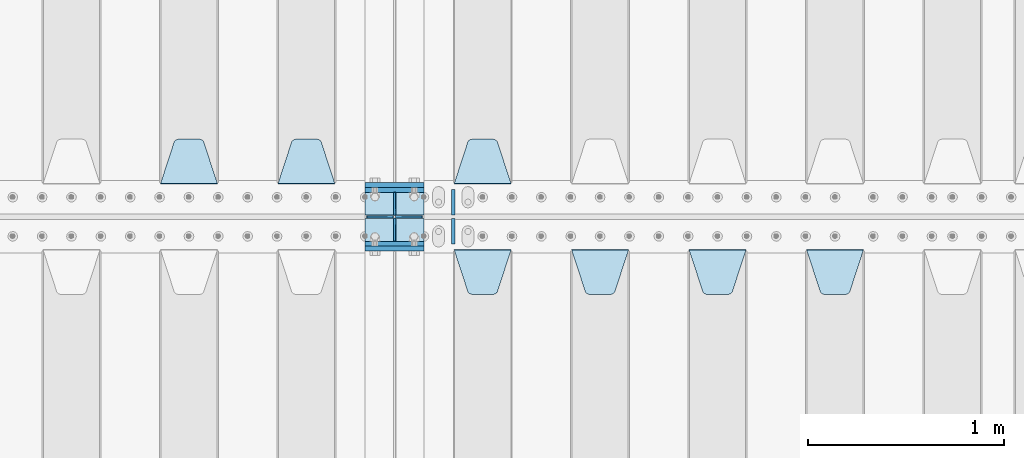
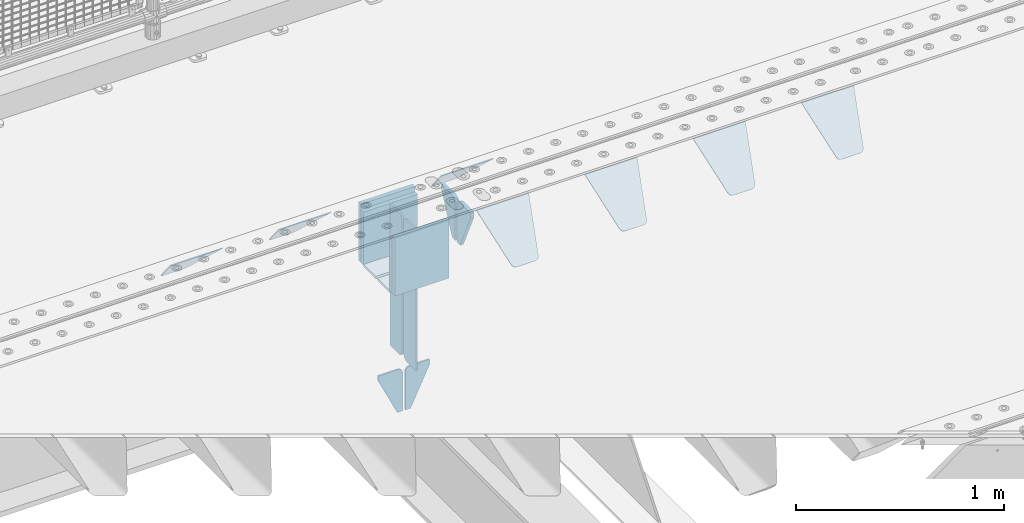
# One storey, part 227 of 257: 21 plates.
"""IFC2X3 building model written with IfcOpenShell, lengths in millimetres."""

from ifc_helpers import new_model, si_unit, frame, origin_with_axes, place, context, subcontext, project, spatial, faceted_brep, material, type_object, element, save


model = new_model("IFC2X3")

# Units and contexts
model_context = context("Model", 3, precision=1e-05, world=origin_with_axes())
body_context = subcontext(model_context, "Body", "Model", "MODEL_VIEW")
ifc_project = project(units=[si_unit("LENGTHUNIT", "METRE", prefix="MILLI"), si_unit("AREAUNIT", "SQUARE_METRE"), si_unit("VOLUMEUNIT", "CUBIC_METRE"), si_unit("MASSUNIT", "GRAM", prefix="KILO"), si_unit("TIMEUNIT", "SECOND"), si_unit("PLANEANGLEUNIT", "RADIAN"), si_unit("SOLIDANGLEUNIT", "STERADIAN"), si_unit("THERMODYNAMICTEMPERATUREUNIT", "DEGREE_CELSIUS"), si_unit("LUMINOUSINTENSITYUNIT", "LUMEN")], contexts=[model_context])

# Site, building, storey
site_placement = place(None, origin_with_axes())
site = spatial("IfcSite", under=ifc_project, at=site_placement, CompositionType="ELEMENT")
building_placement = place(site_placement, origin_with_axes())
building = spatial("IfcBuilding", under=site, at=building_placement, Name="Standard", CompositionType="ELEMENT")
storey_placement = place(building_placement, origin_with_axes())
storey = spatial("IfcBuildingStorey", under=building, at=storey_placement, Name="Undefined", CompositionType="ELEMENT", Elevation=0.0)

# Plates
ifc_material = material(Name="STEEL/S355N")
plate_type_1 = type_object("IfcPlateType", PredefinedType="NOTDEFINED")
for number, where, z_axis, x_axis in (
    (1, (54550.0, 8837.5, -340.000000000044), (0.0, 0.0, 1.0), (1.0, 0.0, 0.0)),
    (2, (54550.0, 9162.5, -340.000000000044), (0.0, 0.0, 1.0), (1.0, 0.0, 0.0)),
):
    element("IfcPlate", number, at=place(storey_placement, frame(where, z_axis=z_axis, x_axis=x_axis)), inside=storey, type_object=plate_type_1, material=ifc_material, context=body_context, shape_type="Brep", body=[
        faceted_brep([(0.0, -12.5, 0.0), (0.0, -12.5, 340.0), (0.0, 12.5, 340.0), (0.0, 12.5, 0.0), (300.0, -12.5, 340.0), (300.0, 12.5, 340.0), (300.0, -12.5, 0.0), (300.0, 12.5, 0.0)], [[[0, 1, 2, 3]], [[1, 4, 5, 2]], [[4, 6, 7, 5]], [[6, 0, 3, 7]], [[5, 7, 3, 2]], [[6, 4, 1, 0]]]),
    ])
for number, where, z_axis, x_axis in (
    (3, (54550.0, 9137.5, -340.0), (0.0, 0.0, 1.0), (1.0, 0.0, 0.0)),
    (4, (54550.0, 8862.5, -340.0), (0.0, 0.0, 1.0), (1.0, 0.0, 0.0)),
):
    element("IfcPlate", number, at=place(storey_placement, frame(where, z_axis=z_axis, x_axis=x_axis)), inside=storey, type_object=plate_type_1, material=ifc_material, context=body_context, shape_type="Brep", body=[
        faceted_brep([(0.0, -12.5, 0.0), (0.0, -12.5, 310.0), (0.0, 12.5, 310.0), (0.0, 12.5, 0.0), (300.0, -12.5, 310.0), (300.0, 12.5, 310.0), (300.0, -12.5, 0.0), (300.0, 12.5, 0.0)], [[[0, 1, 2, 3]], [[1, 4, 5, 2]], [[4, 6, 7, 5]], [[6, 0, 3, 7]], [[5, 7, 3, 2]], [[6, 4, 1, 0]]]),
    ])
plate_type_2 = type_object("IfcPlateType", PredefinedType="NOTDEFINED")
for number, where, z_axis, x_axis in (
    (5, (54550.0, 8992.0, -343.0), (0.0, -1.0, 0.0), (1.0, 0.0, 0.0)),
    (6, (54550.0, 9008.0, -343.0), (0.0, 1.0, 0.0), (1.0, 0.0, 0.0)),
):
    element("IfcPlate", number, at=place(storey_placement, frame(where, z_axis=z_axis, x_axis=x_axis)), inside=storey, type_object=plate_type_2, material=ifc_material, context=body_context, shape_type="Brep", body=[
        faceted_brep([(0.0, -7.0, 0.0), (0.0, -7.0, 117.0), (0.0, 7.0, 117.0), (0.0, 7.0, 0.0), (300.0, -7.0, 117.0), (300.0, 7.0, 117.0), (300.0, -7.0, 0.0), (300.0, 7.0, 0.0)], [[[0, 1, 2, 3]], [[1, 4, 5, 2]], [[4, 6, 7, 5]], [[6, 0, 3, 7]], [[5, 7, 3, 2]], [[6, 4, 1, 0]]]),
    ])
plate_type_3 = type_object("IfcPlateType", PredefinedType="NOTDEFINED")
for number, where, z_axis, x_axis in (
    (7, (54700.0, 8992.0, -350.0), (0.0, 0.0, -1.0), (0.0, -1.0, 0.0)),
    (8, (54700.0, 9008.0, -350.0), (0.0, 0.0, -1.0), (0.0, 1.0, 0.0)),
):
    element("IfcPlate", number, at=place(storey_placement, frame(where, z_axis=z_axis, x_axis=x_axis)), inside=storey, type_object=plate_type_3, material=ifc_material, context=body_context, shape_type="Brep", body=[
        faceted_brep([(0.0, -5.0, 0.0), (0.0, -5.0, 480.0), (0.0, 5.0, 480.0), (0.0, 5.0, 0.0), (0.455767409633609, -5.0, 485.209445330008), (0.455767409633609, 5.0, 485.209445330008), (1.80922137642256, -5.0, 490.26060429977), (1.80922137642256, 5.0, 490.26060429977), (4.01923788646673, -5.0, 495.0), (4.01923788646673, 5.0, 495.0), (7.01866670643085, -5.0, 499.283628290596), (7.01866670643085, 5.0, 499.283628290596), (10.716371709404, -5.0, 502.981333293569), (10.716371709404, 5.0, 502.981333293569), (15.0, -5.0, 505.980762113533), (15.0, 5.0, 505.980762113533), (19.73939570023, -5.0, 508.190778623577), (19.73939570023, 5.0, 508.190778623577), (24.7905546699922, -5.0, 509.544232590366), (24.7905546699922, 5.0, 509.544232590366), (30.0, -5.0, 510.0), (30.0, 5.0, 510.0), (117.0, -5.0, 510.0), (117.0, 5.0, 510.0), (117.0, -5.0, 0.0), (117.0, 5.0, 0.0)], [[[0, 1, 2, 3]], [[1, 4, 5, 2]], [[4, 6, 7, 5]], [[6, 8, 9, 7]], [[8, 10, 11, 9]], [[10, 12, 13, 11]], [[12, 14, 15, 13]], [[14, 16, 17, 15]], [[16, 18, 19, 17]], [[18, 20, 21, 19]], [[20, 22, 23, 21]], [[22, 24, 25, 23]], [[24, 0, 3, 25]], [[5, 7, 9, 11, 13, 15, 17, 19, 21, 23, 25, 3, 2]], [[24, 22, 20, 18, 16, 14, 12, 10, 8, 6, 4, 1, 0]]]),
    ])
for number, where, z_axis, x_axis in (
    (9, (54700.0, 9008.0, -30.0), (0.0, 0.0, -1.0), (0.0, 1.0, 0.0)),
    (10, (54700.0, 8992.0, -30.0), (0.0, 0.0, -1.0), (0.0, -1.0, 0.0)),
):
    element("IfcPlate", number, at=place(storey_placement, frame(where, z_axis=z_axis, x_axis=x_axis)), inside=storey, type_object=plate_type_3, material=ifc_material, context=body_context, shape_type="Brep", body=[
        faceted_brep([(0.0, -5.0, 30.0), (0.0, -5.0, 306.0), (0.0, 5.0, 306.0), (0.0, 5.0, 30.0), (117.0, -5.0, 306.0), (117.0, 5.0, 306.0), (117.0, -5.0, 0.0), (117.0, 5.0, 0.0), (30.0, -5.0, 0.0), (30.0, 5.0, 0.0), (24.7905546699922, -5.0, 0.455767409633758), (24.7905546699922, 5.0, 0.455767409633758), (19.7393957002296, -5.0, 1.80922137642275), (19.7393957002296, 5.0, 1.80922137642275), (15.0, -5.0, 4.01923788646684), (15.0, 5.0, 4.01923788646684), (10.7163717094036, -5.0, 7.01866670643066), (10.7163717094036, 5.0, 7.01866670643066), (7.01866670643085, -5.0, 10.7163717094038), (7.01866670643085, 5.0, 10.7163717094038), (4.01923788646673, -5.0, 15.0), (4.01923788646673, 5.0, 15.0), (1.80922137642301, -5.0, 19.7393957002299), (1.80922137642301, 5.0, 19.7393957002299), (0.455767409634063, -5.0, 24.7905546699921), (0.455767409634063, 5.0, 24.7905546699921)], [[[0, 1, 2, 3]], [[1, 4, 5, 2]], [[4, 6, 7, 5]], [[6, 8, 9, 7]], [[8, 10, 11, 9]], [[10, 12, 13, 11]], [[12, 14, 15, 13]], [[14, 16, 17, 15]], [[16, 18, 19, 17]], [[18, 20, 21, 19]], [[20, 22, 23, 21]], [[22, 24, 25, 23]], [[24, 0, 3, 25]], [[5, 7, 9, 11, 13, 15, 17, 19, 21, 23, 25, 3, 2]], [[24, 22, 20, 18, 16, 14, 12, 10, 8, 6, 4, 1, 0]]]),
    ])
plate_type_4 = type_object("IfcPlateType", PredefinedType="NOTDEFINED")
for number, where, z_axis, x_axis in (
    (11, (54693.499999997, 9000.00000000422, -915.000019536854), (0.0, 0.0, -1.0), (-1.0, 0.0, 0.0)),
    (12, (54706.4999999972, 9000.0000000042, -915.000019536855), (0.0, 0.0, -1.0), (1.0, 0.0, 0.0)),
):
    element("IfcPlate", number, at=place(storey_placement, frame(where, z_axis=z_axis, x_axis=x_axis)), inside=storey, type_object=plate_type_4, material=ifc_material, context=body_context, shape_type="Brep", body=[
        faceted_brep([(0.0, -5.0, 27.0), (0.0, -5.0, 250.0), (0.0, 5.0, 250.0), (0.0, 5.0, 27.0), (30.0, -5.0, 250.0), (30.0, 5.0, 250.0), (135.0, -5.0, 30.0), (135.0, 5.0, 30.0), (135.0, -5.0, 0.0), (135.0, 5.0, 0.0), (27.0, -5.0, 0.0), (27.0, 5.0, 0.0), (22.311499202995, -5.0, 0.410190668670339), (22.311499202995, 5.0, 0.410190668670339), (17.7654561302043, -5.0, 1.62829923878053), (17.7654561302043, 5.0, 1.62829923878053), (13.5, -5.0, 3.6173140978201), (13.5, 5.0, 3.6173140978201), (9.64473453846585, -5.0, 6.31680003578754), (9.64473453846585, 5.0, 6.31680003578754), (6.31680003579095, -5.0, 9.64473453846347), (6.31680003579095, 5.0, 9.64473453846347), (3.61731409782078, -5.0, 13.5), (3.61731409782078, 5.0, 13.5), (1.62829923877871, -5.0, 17.765456130207), (1.62829923877871, 5.0, 17.765456130207), (0.410190668670111, -5.0, 22.3114992029929), (0.410190668670111, 5.0, 22.3114992029929)], [[[0, 1, 2, 3]], [[1, 4, 5, 2]], [[4, 6, 7, 5]], [[6, 8, 9, 7]], [[8, 10, 11, 9]], [[10, 12, 13, 11]], [[12, 14, 15, 13]], [[14, 16, 17, 15]], [[16, 18, 19, 17]], [[18, 20, 21, 19]], [[20, 22, 23, 21]], [[22, 24, 25, 23]], [[24, 26, 27, 25]], [[26, 0, 3, 27]], [[5, 7, 9, 11, 13, 15, 17, 19, 21, 23, 25, 27, 3, 2]], [[26, 24, 22, 20, 18, 16, 14, 12, 10, 8, 6, 4, 1, 0]]]),
    ])
plate_type_5 = type_object("IfcPlateType", PredefinedType="NOTDEFINED")
plate_1_placement = place(storey_placement, frame((56805.0, 8831.76776695594, -1.767766952965), z_axis=(0.0, -0.707106781186548, -0.707106781186547), x_axis=(1.0, 0.0, 0.0)))
element("IfcPlate", 13, at=plate_1_placement, inside=storey, type_object=plate_type_5, material=ifc_material, context=body_context, shape_type="Brep", body=[
    faceted_brep([(0.0, -2.5, 0.0), (69.345504679477, -2.50000000000091, 300.17173142483), (69.345504679477, 2.5, 300.171731424831), (0.0, 2.5, 0.0), (70.927406119954, -2.50000000000091, 304.8974424154), (70.927406119954, 2.5, 304.8974424154), (73.3818627772271, -2.50000000000091, 309.234538108527), (73.3818627772271, 2.49999999999909, 309.234538108527), (76.6187032999587, -2.5, 313.023683126103), (76.6187032999587, 2.5, 313.023683126103), (80.5190132705029, -2.5, 316.125672595372), (80.5190132705029, 2.5, 316.125672595371), (84.9395038596849, -2.5, 318.426546230476), (84.9395038596849, 2.5, 318.426546230477), (89.7177759439219, -2.5, 319.841774983275), (89.7177759439219, 2.5, 319.841774983275), (94.6782862926484, -2.5, 320.319366455079), (94.6782862926484, 2.5, 320.319366455079), (195.321713707352, -2.5, 320.319366455079), (195.321713707352, 2.5, 320.319366455079), (200.282224056078, -2.5, 319.841774983275), (200.282224056078, 2.49999999999909, 319.841774983275), (205.060496140315, -2.5, 318.426546230476), (205.060496140315, 2.49999999999909, 318.426546230475), (209.480986729497, -2.5, 316.125672595371), (209.480986729497, 2.5, 316.125672595371), (213.381296700041, -2.50000000000091, 313.023683126102), (213.381296700041, 2.5, 313.023683126103), (216.618137222766, -2.50000000000091, 309.234538108527), (216.618137222766, 2.5, 309.234538108527), (219.072593880039, -2.5, 304.897442415399), (219.072593880039, 2.5, 304.897442415399), (220.654495320523, -2.50000000000091, 300.17173142483), (220.654495320523, 2.5, 300.171731424831), (290.0, -2.50000000000091, 0.0), (290.0, 2.5, 9.09494701772928e-13)], [[[0, 1, 2, 3]], [[1, 4, 5, 2]], [[4, 6, 7, 5]], [[6, 8, 9, 7]], [[8, 10, 11, 9]], [[10, 12, 13, 11]], [[12, 14, 15, 13]], [[14, 16, 17, 15]], [[16, 18, 19, 17]], [[18, 20, 21, 19]], [[20, 22, 23, 21]], [[22, 24, 25, 23]], [[24, 26, 27, 25]], [[26, 28, 29, 27]], [[28, 30, 31, 29]], [[30, 32, 33, 31]], [[32, 34, 35, 33]], [[34, 0, 3, 35]], [[5, 7, 9, 11, 13, 15, 17, 19, 21, 23, 25, 27, 29, 31, 33, 35, 3, 2]], [[34, 32, 30, 28, 26, 24, 22, 20, 18, 16, 14, 12, 10, 8, 6, 4, 1, 0]]]),
])
plate_2_placement = place(storey_placement, frame((56205.0, 8831.76776695594, -1.767766952965), z_axis=(0.0, -0.707106781186548, -0.707106781186547), x_axis=(1.0, 0.0, 0.0)))
element("IfcPlate", 14, at=plate_2_placement, inside=storey, type_object=plate_type_5, material=ifc_material, context=body_context, shape_type="Brep", body=[
    faceted_brep([(0.0, -2.5, 0.0), (69.345504679477, -2.50000000000091, 300.17173142483), (69.345504679477, 2.5, 300.171731424831), (0.0, 2.5, 0.0), (70.927406119954, -2.50000000000091, 304.8974424154), (70.927406119954, 2.5, 304.8974424154), (73.3818627772271, -2.50000000000091, 309.234538108527), (73.3818627772271, 2.49999999999909, 309.234538108527), (76.6187032999587, -2.5, 313.023683126103), (76.6187032999587, 2.5, 313.023683126103), (80.5190132705029, -2.5, 316.125672595372), (80.5190132705029, 2.5, 316.125672595371), (84.9395038596849, -2.5, 318.426546230476), (84.9395038596849, 2.5, 318.426546230477), (89.7177759439219, -2.5, 319.841774983275), (89.7177759439219, 2.5, 319.841774983275), (94.6782862926484, -2.5, 320.319366455079), (94.6782862926484, 2.5, 320.319366455079), (195.321713707352, -2.5, 320.319366455079), (195.321713707352, 2.5, 320.319366455079), (200.282224056078, -2.5, 319.841774983275), (200.282224056078, 2.49999999999909, 319.841774983275), (205.060496140315, -2.5, 318.426546230476), (205.060496140315, 2.49999999999909, 318.426546230475), (209.480986729497, -2.5, 316.125672595371), (209.480986729497, 2.5, 316.125672595371), (213.381296700041, -2.50000000000091, 313.023683126102), (213.381296700041, 2.5, 313.023683126103), (216.618137222766, -2.50000000000091, 309.234538108527), (216.618137222766, 2.5, 309.234538108527), (219.072593880039, -2.5, 304.897442415399), (219.072593880039, 2.5, 304.897442415399), (220.654495320523, -2.50000000000091, 300.17173142483), (220.654495320523, 2.5, 300.171731424831), (290.0, -2.50000000000091, 0.0), (290.0, 2.5, 9.09494701772928e-13)], [[[0, 1, 2, 3]], [[1, 4, 5, 2]], [[4, 6, 7, 5]], [[6, 8, 9, 7]], [[8, 10, 11, 9]], [[10, 12, 13, 11]], [[12, 14, 15, 13]], [[14, 16, 17, 15]], [[16, 18, 19, 17]], [[18, 20, 21, 19]], [[20, 22, 23, 21]], [[22, 24, 25, 23]], [[24, 26, 27, 25]], [[26, 28, 29, 27]], [[28, 30, 31, 29]], [[30, 32, 33, 31]], [[32, 34, 35, 33]], [[34, 0, 3, 35]], [[5, 7, 9, 11, 13, 15, 17, 19, 21, 23, 25, 27, 29, 31, 33, 35, 3, 2]], [[34, 32, 30, 28, 26, 24, 22, 20, 18, 16, 14, 12, 10, 8, 6, 4, 1, 0]]]),
])
plate_3_placement = place(storey_placement, frame((55605.0, 8831.76776695594, -1.767766952965), z_axis=(0.0, -0.707106781186548, -0.707106781186547), x_axis=(1.0, 0.0, 0.0)))
element("IfcPlate", 15, at=plate_3_placement, inside=storey, type_object=plate_type_5, material=ifc_material, context=body_context, shape_type="Brep", body=[
    faceted_brep([(0.0, -2.5, 0.0), (69.345504679477, -2.50000000000091, 300.17173142483), (69.345504679477, 2.5, 300.171731424831), (0.0, 2.5, 0.0), (70.927406119954, -2.50000000000091, 304.8974424154), (70.927406119954, 2.5, 304.8974424154), (73.3818627772271, -2.50000000000091, 309.234538108527), (73.3818627772271, 2.49999999999909, 309.234538108527), (76.6187032999587, -2.5, 313.023683126103), (76.6187032999587, 2.5, 313.023683126103), (80.5190132705029, -2.5, 316.125672595372), (80.5190132705029, 2.5, 316.125672595371), (84.9395038596849, -2.5, 318.426546230476), (84.9395038596849, 2.5, 318.426546230477), (89.7177759439219, -2.5, 319.841774983275), (89.7177759439219, 2.5, 319.841774983275), (94.6782862926484, -2.5, 320.319366455079), (94.6782862926484, 2.5, 320.319366455079), (195.321713707352, -2.5, 320.319366455079), (195.321713707352, 2.5, 320.319366455079), (200.282224056078, -2.5, 319.841774983275), (200.282224056078, 2.49999999999909, 319.841774983275), (205.060496140315, -2.5, 318.426546230476), (205.060496140315, 2.49999999999909, 318.426546230475), (209.480986729497, -2.5, 316.125672595371), (209.480986729497, 2.5, 316.125672595371), (213.381296700041, -2.50000000000091, 313.023683126102), (213.381296700041, 2.5, 313.023683126103), (216.618137222766, -2.50000000000091, 309.234538108527), (216.618137222766, 2.5, 309.234538108527), (219.072593880039, -2.5, 304.897442415399), (219.072593880039, 2.5, 304.897442415399), (220.654495320523, -2.50000000000091, 300.17173142483), (220.654495320523, 2.5, 300.171731424831), (290.0, -2.50000000000091, 0.0), (290.0, 2.5, 9.09494701772928e-13)], [[[0, 1, 2, 3]], [[1, 4, 5, 2]], [[4, 6, 7, 5]], [[6, 8, 9, 7]], [[8, 10, 11, 9]], [[10, 12, 13, 11]], [[12, 14, 15, 13]], [[14, 16, 17, 15]], [[16, 18, 19, 17]], [[18, 20, 21, 19]], [[20, 22, 23, 21]], [[22, 24, 25, 23]], [[24, 26, 27, 25]], [[26, 28, 29, 27]], [[28, 30, 31, 29]], [[30, 32, 33, 31]], [[32, 34, 35, 33]], [[34, 0, 3, 35]], [[5, 7, 9, 11, 13, 15, 17, 19, 21, 23, 25, 27, 29, 31, 33, 35, 3, 2]], [[34, 32, 30, 28, 26, 24, 22, 20, 18, 16, 14, 12, 10, 8, 6, 4, 1, 0]]]),
])
plate_4_placement = place(storey_placement, frame((55005.0, 8831.76776695594, -1.767766952965), z_axis=(0.0, -0.707106781186548, -0.707106781186547), x_axis=(1.0, 0.0, 0.0)))
element("IfcPlate", 16, at=plate_4_placement, inside=storey, type_object=plate_type_5, material=ifc_material, context=body_context, shape_type="Brep", body=[
    faceted_brep([(0.0, -2.5, 0.0), (69.345504679477, -2.50000000000091, 300.17173142483), (69.345504679477, 2.5, 300.171731424831), (0.0, 2.5, 0.0), (70.927406119954, -2.50000000000091, 304.8974424154), (70.927406119954, 2.5, 304.8974424154), (73.3818627772271, -2.50000000000091, 309.234538108527), (73.3818627772271, 2.49999999999909, 309.234538108527), (76.6187032999587, -2.5, 313.023683126103), (76.6187032999587, 2.5, 313.023683126103), (80.5190132705029, -2.5, 316.125672595372), (80.5190132705029, 2.5, 316.125672595371), (84.9395038596849, -2.5, 318.426546230476), (84.9395038596849, 2.5, 318.426546230477), (89.7177759439219, -2.5, 319.841774983275), (89.7177759439219, 2.5, 319.841774983275), (94.6782862926484, -2.5, 320.319366455079), (94.6782862926484, 2.5, 320.319366455079), (195.321713707352, -2.5, 320.319366455079), (195.321713707352, 2.5, 320.319366455079), (200.282224056078, -2.5, 319.841774983275), (200.282224056078, 2.49999999999909, 319.841774983275), (205.060496140315, -2.5, 318.426546230476), (205.060496140315, 2.49999999999909, 318.426546230475), (209.480986729497, -2.5, 316.125672595371), (209.480986729497, 2.5, 316.125672595371), (213.381296700041, -2.50000000000091, 313.023683126102), (213.381296700041, 2.5, 313.023683126103), (216.618137222766, -2.50000000000091, 309.234538108527), (216.618137222766, 2.5, 309.234538108527), (219.072593880039, -2.5, 304.897442415399), (219.072593880039, 2.5, 304.897442415399), (220.654495320523, -2.50000000000091, 300.17173142483), (220.654495320523, 2.5, 300.171731424831), (290.0, -2.50000000000091, 0.0), (290.0, 2.5, 9.09494701772928e-13)], [[[0, 1, 2, 3]], [[1, 4, 5, 2]], [[4, 6, 7, 5]], [[6, 8, 9, 7]], [[8, 10, 11, 9]], [[10, 12, 13, 11]], [[12, 14, 15, 13]], [[14, 16, 17, 15]], [[16, 18, 19, 17]], [[18, 20, 21, 19]], [[20, 22, 23, 21]], [[22, 24, 25, 23]], [[24, 26, 27, 25]], [[26, 28, 29, 27]], [[28, 30, 31, 29]], [[30, 32, 33, 31]], [[32, 34, 35, 33]], [[34, 0, 3, 35]], [[5, 7, 9, 11, 13, 15, 17, 19, 21, 23, 25, 27, 29, 31, 33, 35, 3, 2]], [[34, 32, 30, 28, 26, 24, 22, 20, 18, 16, 14, 12, 10, 8, 6, 4, 1, 0]]]),
])
plate_5_placement = place(storey_placement, frame((55295.0, 9168.23223304703, -1.76776695296758), z_axis=(0.0, 0.707106781186547, -0.707106781186548), x_axis=(-1.0, 0.0, 0.0)))
element("IfcPlate", 17, at=plate_5_placement, inside=storey, type_object=plate_type_5, material=ifc_material, context=body_context, shape_type="Brep", body=[
    faceted_brep([(0.0, -2.5, 0.0), (69.345504679477, -2.50000000000091, 300.17173142483), (69.345504679477, 2.5, 300.171731424831), (0.0, 2.5, 0.0), (70.927406119954, -2.50000000000091, 304.8974424154), (70.927406119954, 2.5, 304.8974424154), (73.3818627772271, -2.50000000000091, 309.234538108527), (73.3818627772271, 2.49999999999909, 309.234538108527), (76.6187032999587, -2.5, 313.023683126103), (76.6187032999587, 2.5, 313.023683126103), (80.5190132705029, -2.5, 316.125672595372), (80.5190132705029, 2.5, 316.125672595371), (84.9395038596849, -2.5, 318.426546230476), (84.9395038596849, 2.5, 318.426546230477), (89.7177759439219, -2.5, 319.841774983275), (89.7177759439219, 2.5, 319.841774983275), (94.6782862926484, -2.5, 320.319366455079), (94.6782862926484, 2.5, 320.319366455079), (195.321713707352, -2.5, 320.319366455079), (195.321713707352, 2.5, 320.319366455079), (200.282224056078, -2.5, 319.841774983275), (200.282224056078, 2.49999999999909, 319.841774983275), (205.060496140315, -2.5, 318.426546230476), (205.060496140315, 2.49999999999909, 318.426546230475), (209.480986729497, -2.5, 316.125672595371), (209.480986729497, 2.5, 316.125672595371), (213.381296700041, -2.50000000000091, 313.023683126102), (213.381296700041, 2.5, 313.023683126103), (216.618137222766, -2.50000000000091, 309.234538108527), (216.618137222766, 2.5, 309.234538108527), (219.072593880039, -2.5, 304.897442415399), (219.072593880039, 2.5, 304.897442415399), (220.654495320523, -2.50000000000091, 300.17173142483), (220.654495320523, 2.5, 300.171731424831), (290.0, -2.50000000000091, 0.0), (290.0, 2.5, 9.09494701772928e-13)], [[[0, 1, 2, 3]], [[1, 4, 5, 2]], [[4, 6, 7, 5]], [[6, 8, 9, 7]], [[8, 10, 11, 9]], [[10, 12, 13, 11]], [[12, 14, 15, 13]], [[14, 16, 17, 15]], [[16, 18, 19, 17]], [[18, 20, 21, 19]], [[20, 22, 23, 21]], [[22, 24, 25, 23]], [[24, 26, 27, 25]], [[26, 28, 29, 27]], [[28, 30, 31, 29]], [[30, 32, 33, 31]], [[32, 34, 35, 33]], [[34, 0, 3, 35]], [[5, 7, 9, 11, 13, 15, 17, 19, 21, 23, 25, 27, 29, 31, 33, 35, 3, 2]], [[34, 32, 30, 28, 26, 24, 22, 20, 18, 16, 14, 12, 10, 8, 6, 4, 1, 0]]]),
])
plate_6_placement = place(storey_placement, frame((54395.0, 9168.23223304703, -1.76776695296758), z_axis=(0.0, 0.707106781186547, -0.707106781186548), x_axis=(-1.0, 0.0, 0.0)))
element("IfcPlate", 18, at=plate_6_placement, inside=storey, type_object=plate_type_5, material=ifc_material, context=body_context, shape_type="Brep", body=[
    faceted_brep([(0.0, -2.5, 0.0), (69.345504679477, -2.50000000000091, 300.17173142483), (69.345504679477, 2.5, 300.171731424831), (0.0, 2.5, 0.0), (70.927406119954, -2.50000000000091, 304.8974424154), (70.927406119954, 2.5, 304.8974424154), (73.3818627772271, -2.50000000000091, 309.234538108527), (73.3818627772271, 2.49999999999909, 309.234538108527), (76.6187032999587, -2.5, 313.023683126103), (76.6187032999587, 2.5, 313.023683126103), (80.5190132705029, -2.5, 316.125672595372), (80.5190132705029, 2.5, 316.125672595371), (84.9395038596849, -2.5, 318.426546230476), (84.9395038596849, 2.5, 318.426546230477), (89.7177759439219, -2.5, 319.841774983275), (89.7177759439219, 2.5, 319.841774983275), (94.6782862926484, -2.5, 320.319366455079), (94.6782862926484, 2.5, 320.319366455079), (195.321713707352, -2.5, 320.319366455079), (195.321713707352, 2.5, 320.319366455079), (200.282224056078, -2.5, 319.841774983275), (200.282224056078, 2.49999999999909, 319.841774983275), (205.060496140315, -2.5, 318.426546230476), (205.060496140315, 2.49999999999909, 318.426546230475), (209.480986729497, -2.5, 316.125672595371), (209.480986729497, 2.5, 316.125672595371), (213.381296700041, -2.50000000000091, 313.023683126102), (213.381296700041, 2.5, 313.023683126103), (216.618137222766, -2.50000000000091, 309.234538108527), (216.618137222766, 2.5, 309.234538108527), (219.072593880039, -2.5, 304.897442415399), (219.072593880039, 2.5, 304.897442415399), (220.654495320523, -2.50000000000091, 300.17173142483), (220.654495320523, 2.5, 300.171731424831), (290.0, -2.50000000000091, 0.0), (290.0, 2.5, 9.09494701772928e-13)], [[[0, 1, 2, 3]], [[1, 4, 5, 2]], [[4, 6, 7, 5]], [[6, 8, 9, 7]], [[8, 10, 11, 9]], [[10, 12, 13, 11]], [[12, 14, 15, 13]], [[14, 16, 17, 15]], [[16, 18, 19, 17]], [[18, 20, 21, 19]], [[20, 22, 23, 21]], [[22, 24, 25, 23]], [[24, 26, 27, 25]], [[26, 28, 29, 27]], [[28, 30, 31, 29]], [[30, 32, 33, 31]], [[32, 34, 35, 33]], [[34, 0, 3, 35]], [[5, 7, 9, 11, 13, 15, 17, 19, 21, 23, 25, 27, 29, 31, 33, 35, 3, 2]], [[34, 32, 30, 28, 26, 24, 22, 20, 18, 16, 14, 12, 10, 8, 6, 4, 1, 0]]]),
])
plate_7_placement = place(storey_placement, frame((53795.0, 9168.23223304703, -1.76776695296758), z_axis=(0.0, 0.707106781186547, -0.707106781186548), x_axis=(-1.0, 0.0, 0.0)))
element("IfcPlate", 19, at=plate_7_placement, inside=storey, type_object=plate_type_5, material=ifc_material, context=body_context, shape_type="Brep", body=[
    faceted_brep([(0.0, -2.5, 0.0), (69.345504679477, -2.50000000000091, 300.17173142483), (69.345504679477, 2.5, 300.171731424831), (0.0, 2.5, 0.0), (70.927406119954, -2.50000000000091, 304.8974424154), (70.927406119954, 2.5, 304.8974424154), (73.3818627772271, -2.50000000000091, 309.234538108527), (73.3818627772271, 2.49999999999909, 309.234538108527), (76.6187032999587, -2.5, 313.023683126103), (76.6187032999587, 2.5, 313.023683126103), (80.5190132705029, -2.5, 316.125672595372), (80.5190132705029, 2.5, 316.125672595371), (84.9395038596849, -2.5, 318.426546230476), (84.9395038596849, 2.5, 318.426546230477), (89.7177759439219, -2.5, 319.841774983275), (89.7177759439219, 2.5, 319.841774983275), (94.6782862926484, -2.5, 320.319366455079), (94.6782862926484, 2.5, 320.319366455079), (195.321713707352, -2.5, 320.319366455079), (195.321713707352, 2.5, 320.319366455079), (200.282224056078, -2.5, 319.841774983275), (200.282224056078, 2.49999999999909, 319.841774983275), (205.060496140315, -2.5, 318.426546230476), (205.060496140315, 2.49999999999909, 318.426546230475), (209.480986729497, -2.5, 316.125672595371), (209.480986729497, 2.5, 316.125672595371), (213.381296700041, -2.50000000000091, 313.023683126102), (213.381296700041, 2.5, 313.023683126103), (216.618137222766, -2.50000000000091, 309.234538108527), (216.618137222766, 2.5, 309.234538108527), (219.072593880039, -2.5, 304.897442415399), (219.072593880039, 2.5, 304.897442415399), (220.654495320523, -2.50000000000091, 300.17173142483), (220.654495320523, 2.5, 300.171731424831), (290.0, -2.50000000000091, 0.0), (290.0, 2.5, 9.09494701772928e-13)], [[[0, 1, 2, 3]], [[1, 4, 5, 2]], [[4, 6, 7, 5]], [[6, 8, 9, 7]], [[8, 10, 11, 9]], [[10, 12, 13, 11]], [[12, 14, 15, 13]], [[14, 16, 17, 15]], [[16, 18, 19, 17]], [[18, 20, 21, 19]], [[20, 22, 23, 21]], [[22, 24, 25, 23]], [[24, 26, 27, 25]], [[26, 28, 29, 27]], [[28, 30, 31, 29]], [[30, 32, 33, 31]], [[32, 34, 35, 33]], [[34, 0, 3, 35]], [[5, 7, 9, 11, 13, 15, 17, 19, 21, 23, 25, 27, 29, 31, 33, 35, 3, 2]], [[34, 32, 30, 28, 26, 24, 22, 20, 18, 16, 14, 12, 10, 8, 6, 4, 1, 0]]]),
])
plate_type_6 = type_object("IfcPlateType", PredefinedType="NOTDEFINED")
for number, where, z_axis, x_axis in (
    (20, (55000.0, 8860.0, -30.0), (0.0, 0.0, -1.0), (0.0, 1.0, 0.0)),
    (21, (55000.0, 9140.0, -30.0), (0.0, 0.0, -1.0), (0.0, -1.0, 0.0)),
):
    element("IfcPlate", number, at=place(storey_placement, frame(where, z_axis=z_axis, x_axis=x_axis)), inside=storey, type_object=plate_type_6, material=ifc_material, context=body_context, shape_type="Brep", body=[
        faceted_brep([(0.0, -10.0, 0.0), (0.0, -10.0, 30.0), (0.0, 10.0, 30.0), (0.0, 10.0, 0.0), (102.0, -10.0, 250.0), (102.0, 10.0, 250.0), (132.0, -10.0, 250.0), (132.0, 10.0, 250.0), (132.0, -10.0, 30.0), (132.0, 10.0, 30.0), (131.544232590366, -10.0, 24.790554669992), (131.544232590366, 10.0, 24.790554669992), (130.190778623577, -10.0, 19.7393957002299), (130.190778623577, 10.0, 19.7393957002299), (127.980762113533, -10.0, 15.0), (127.980762113533, 10.0, 15.0), (124.981333293569, -10.0, 10.7163717094038), (124.981333293569, 10.0, 10.7163717094038), (121.283628290596, -10.0, 7.01866670643062), (121.283628290596, 10.0, 7.01866670643062), (117.0, -10.0, 4.01923788646684), (117.0, 10.0, 4.01923788646684), (112.26060429977, -10.0, 1.80922137642278), (112.26060429977, 10.0, 1.80922137642278), (107.209445330008, -10.0, 0.455767409633722), (107.209445330008, 10.0, 0.455767409633722), (102.0, -10.0, 0.0), (102.0, 10.0, 0.0)], [[[0, 1, 2, 3]], [[1, 4, 5, 2]], [[4, 6, 7, 5]], [[6, 8, 9, 7]], [[8, 10, 11, 9]], [[10, 12, 13, 11]], [[12, 14, 15, 13]], [[14, 16, 17, 15]], [[16, 18, 19, 17]], [[18, 20, 21, 19]], [[20, 22, 23, 21]], [[22, 24, 25, 23]], [[24, 26, 27, 25]], [[26, 0, 3, 27]], [[5, 7, 9, 11, 13, 15, 17, 19, 21, 23, 25, 27, 3, 2]], [[26, 24, 22, 20, 18, 16, 14, 12, 10, 8, 6, 4, 1, 0]]]),
    ])

save(model, "model.ifc")
